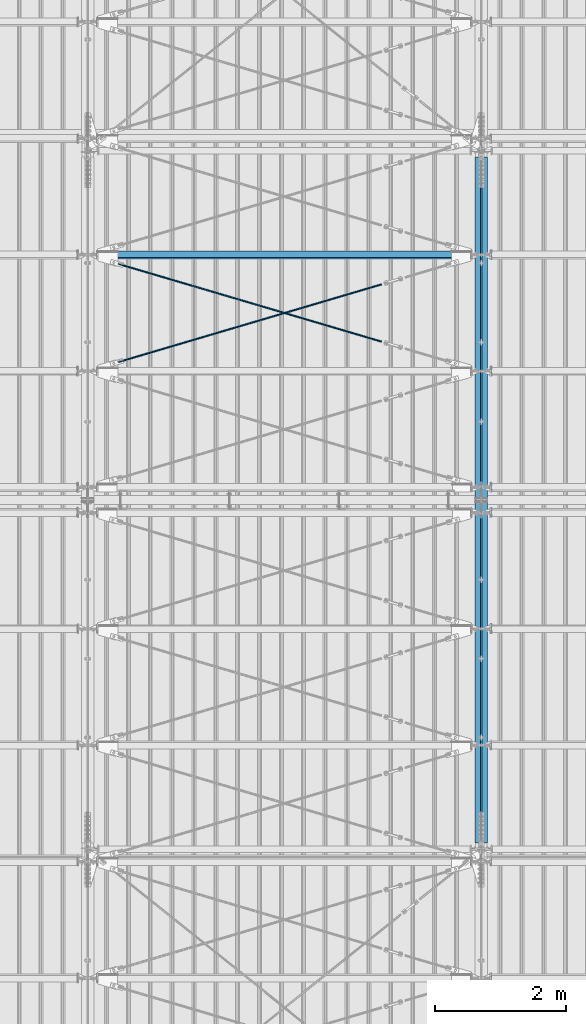
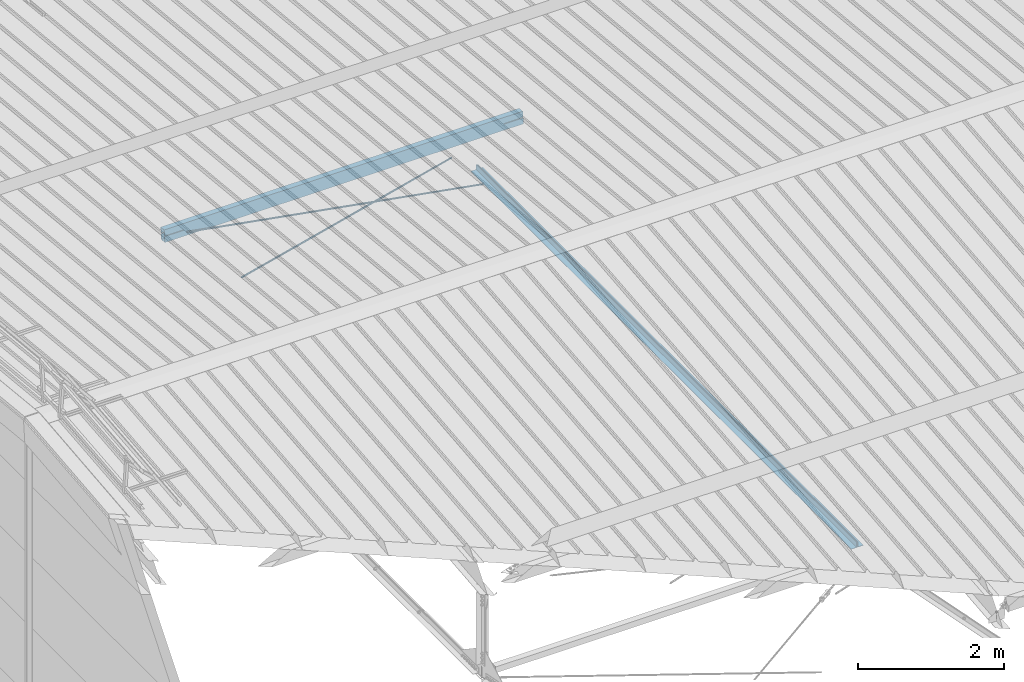
# One storey, part 249 of 709: 5 beams, 4 openings, 5 elements without a shape of their own.
"""IFC4 building model written with IfcOpenShell, lengths in millimetres."""

from ifc_helpers import new_model, si_unit, direction, frame, origin_with_axes, place, context, subcontext, project, spatial, line, indexed_curve, outline, extrude, polygons, material, element, aggregate, save


model = new_model("IFC4")

# Units and contexts
model_context = context("Model", 3, precision=0.2, world=origin_with_axes(), true_north=direction((0.0, 1.0)))
body_context = subcontext(model_context, "Body", "Model", "MODEL_VIEW")
reference_context = subcontext(model_context, "Reference", "Model", "MODEL_VIEW")
ifc_project = project(units=[si_unit("LENGTHUNIT", "METRE", prefix="MILLI"), si_unit("AREAUNIT", "SQUARE_METRE"), si_unit("VOLUMEUNIT", "CUBIC_METRE"), si_unit("MASSUNIT", "GRAM", prefix="KILO"), si_unit("TIMEUNIT", "SECOND"), si_unit("PLANEANGLEUNIT", "RADIAN"), si_unit("SOLIDANGLEUNIT", "STERADIAN"), si_unit("THERMODYNAMICTEMPERATUREUNIT", "DEGREE_CELSIUS"), si_unit("LUMINOUSINTENSITYUNIT", "LUMEN")], contexts=[model_context])

# Site, building, storey
site_placement = place(None, origin_with_axes())
site = spatial("IfcSite", under=ifc_project, at=site_placement, CompositionType="ELEMENT")
building_placement = place(site_placement, origin_with_axes())
building = spatial("IfcBuilding", under=site, at=building_placement, Name="Undefined", CompositionType="ELEMENT")
storey_placement = place(building_placement, origin_with_axes())
storey = spatial("IfcBuildingStorey", under=building, at=storey_placement, Name="Undefined", CompositionType="ELEMENT", Elevation=0.0)

# Assembly, beam
assembly_1_placement = place(storey_placement, frame((9949.0, 5673.0, 6045.00002), z_axis=(0.0, 0.0, 1.0), x_axis=(0.0, 1.0, 0.0)))
assembly_1 = element("IfcElementAssembly", 1, at=assembly_1_placement, inside=storey)
ifc_material_1 = material(Name="C345-5", Category="STEEL")
beam_1_placement = place(assembly_1_placement, origin_with_axes())
beam_1 = element("IfcBeam", 2, at=beam_1_placement, material=ifc_material_1, ObjectType="433", context=body_context, shape_type="Tessellation", body=[
    polygons([(100.0, -45.0, -45.0), (100.0, 45.0, -45.0), (10554.0, 45.0, -45.0), (10554.0, -45.0, -45.0), (100.0, 45.0, -39.0), (10554.0, 45.0, -39.0), (100.0, -39.0, -39.0), (10554.0, -39.0, -39.0), (100.0, -39.0, 45.0), (10554.0, -39.0, 45.0), (100.0, -45.0, 45.0), (10554.0, -45.0, 45.0)], [[[1, 2, 3, 4]], [[2, 5, 6, 3]], [[5, 7, 8, 6]], [[7, 9, 10, 8]], [[9, 11, 12, 10]], [[11, 1, 4, 12]], [[6, 8, 10, 12, 4, 3]], [[11, 9, 7, 5, 2, 1]]], closed=True),
])
aggregate(assembly_1, [beam_1])

assembly_2_placement = place(storey_placement, frame((10051.0, 16327.0, 6045.00002), z_axis=(0.0, 0.0, 1.0), x_axis=(0.0, -1.0, 0.0)))
assembly_2 = element("IfcElementAssembly", 3, at=assembly_2_placement, inside=storey)
beam_2_placement = place(assembly_2_placement, origin_with_axes())
beam_2 = element("IfcBeam", 4, at=beam_2_placement, material=ifc_material_1, ObjectType="434", context=body_context, shape_type="Tessellation", body=[
    polygons([(100.0, -45.0, -45.0), (100.0, 45.0, -45.0), (10554.0, 45.0, -45.0), (10554.0, -45.0, -45.0), (100.0, 45.0, -39.0), (10554.0, 45.0, -39.0), (100.0, -39.0, -39.0), (10554.0, -39.0, -39.0), (100.0, -39.0, 45.0), (10554.0, -39.0, 45.0), (100.0, -45.0, 45.0), (10554.0, -45.0, 45.0)], [[[1, 2, 3, 4]], [[2, 5, 6, 3]], [[5, 7, 8, 6]], [[7, 9, 10, 8]], [[9, 11, 12, 10]], [[11, 1, 4, 12]], [[6, 8, 10, 12, 4, 3]], [[11, 9, 7, 5, 2, 1]]], closed=True),
])
aggregate(assembly_2, [beam_2])

# Assembly, beam, voiding feature
assembly_3_placement = place(storey_placement, frame((4000.0, 12964.14591, 8040.08943), z_axis=(0.2847296511, -0.9538504697, 0.095385047), x_axis=(0.9586078582, 0.2833165921, -0.028331659)))
assembly_3 = element("IfcElementAssembly", 5, at=assembly_3_placement, inside=storey)
ifc_material_2 = material(Name="C355-5", Category="STEEL")
beam_3_placement = place(assembly_3_placement, origin_with_axes())
beam_3 = element("IfcBeam", 6, at=beam_3_placement, material=ifc_material_2, ObjectType="572", context=body_context, shape_type="Tessellation", body=[
    polygons([(4849.07659, 7.36122, 4.25), (4849.07659, 6.01041, 6.01041), (4849.07659, 4.25, 7.36122), (4849.07659, 2.19996, 8.21037), (4849.07659, 0.0, 8.5), (4849.07659, -2.19996, 8.21037), (4849.07659, -4.25, 7.36122), (4849.07659, -6.01041, 6.01041), (4849.07659, -7.36121, 4.25), (4849.07659, -8.21037, 2.19996), (4849.07659, -8.5, 0.0), (4849.07659, -8.21037, -2.19996), (4849.07659, -7.36121, -4.25), (4849.07659, -6.01041, -6.01041), (4849.07659, -4.25, -7.36122), (4849.07659, -2.19996, -8.21037), (4849.07659, 0.0, -8.5), (4849.07659, 2.19996, -8.21037), (4849.07659, 4.25, -7.36122), (4849.07659, 6.01041, -6.01041), (4849.07659, 7.36122, -4.25), (4849.07659, 8.21037, -2.19996), (4849.07659, 8.5, 0.0), (4849.07659, 8.21037, 2.19996), (4669.07659, 8.21037, 2.19996), (4669.07659, 7.36122, 4.25), (4669.07659, 6.01041, 6.01041), (4669.07659, 4.25, 7.36122), (4669.07659, 2.19996, 8.21037), (4669.07659, 0.0, 8.5), (4669.07659, -2.19996, 8.21037), (4669.07659, -4.25, 7.36122), (4669.07659, -6.01041, 6.01041), (4669.07659, -7.36121, 4.25), (4669.07659, -8.21037, 2.19996), (4669.07659, -8.5, 0.0), (4669.07659, -8.21037, -2.19996), (4669.07659, -7.36121, -4.25), (4669.07659, -6.01041, -6.01041), (4669.07659, -4.25, -7.36122), (4669.07659, -2.19996, -8.21037), (4669.07659, 0.0, -8.5), (4669.07659, 2.19996, -8.21037), (4669.07659, 4.25, -7.36122), (4669.07659, 6.01041, -6.01041), (4669.07659, 7.36122, -4.25), (4669.07659, 8.21037, -2.19996), (4669.07659, 8.5, 0.0), (4669.07659, 10.0, 0.0), (4669.07659, 9.65926, 2.58819), (4669.07659, 8.66025, 5.0), (4669.07659, 7.07107, 7.07107), (4669.07659, 5.0, 8.66025), (4669.07659, 2.58819, 9.65926), (4669.07659, 0.0, 10.0), (4669.07659, -2.58819, 9.65926), (4669.07659, -5.0, 8.66025), (4669.07659, -7.07107, 7.07107), (4669.07659, -8.66025, 5.0), (4669.07659, -9.65926, 2.58819), (4669.07659, -10.0, 0.0), (4669.07659, -9.65926, -2.58819), (4669.07659, -8.66025, -5.0), (4669.07659, -7.07107, -7.07107), (4669.07659, -5.0, -8.66025), (4669.07659, -2.58819, -9.65926), (4669.07659, 0.0, -10.0), (4669.07659, 2.58819, -9.65926), (4669.07659, 5.0, -8.66025), (4669.07659, 7.07107, -7.07107), (4669.07659, 8.66025, -5.0), (4669.07659, 9.65926, -2.58819), (483.68279, 2.58819, 9.65926), (483.68279, 5.0, 8.66025), (483.68279, 7.07107, 7.07107), (483.68279, 8.66025, 5.0), (483.68279, 9.65926, 2.58819), (483.68279, 10.0, 0.0), (483.68279, 9.65926, -2.58819), (483.68279, 8.66025, -5.0), (483.68279, 7.07107, -7.07107), (483.68279, 5.0, -8.66025), (483.68279, 2.58819, -9.65926), (483.68279, 0.0, -10.0), (483.68279, -2.58819, -9.65926), (483.68279, -5.0, -8.66025), (483.68279, -7.07107, -7.07107), (483.68279, -8.66025, -5.0), (483.68279, -9.65926, -2.58819), (483.68279, -10.0, 0.0), (483.68279, -9.65926, 2.58819), (483.68279, -8.66025, 5.0), (483.68279, -7.07107, 7.07107), (483.68279, -5.0, 8.66025), (483.68279, -2.58819, 9.65926), (483.68279, 0.0, 10.0)], [[[1, 2, 3, 4, 5, 6, 7, 8, 9, 10, 11, 12, 13, 14, 15, 16, 17, 18, 19, 20, 21, 22, 23, 24]], [[24, 25, 26, 1]], [[1, 26, 27, 2]], [[2, 27, 28, 3]], [[3, 28, 29, 4]], [[4, 29, 30, 5]], [[5, 30, 31, 6]], [[6, 31, 32, 7]], [[7, 32, 33, 8]], [[8, 33, 34, 9]], [[9, 34, 35, 10]], [[10, 35, 36, 11]], [[11, 36, 37, 12]], [[12, 37, 38, 13]], [[13, 38, 39, 14]], [[14, 39, 40, 15]], [[15, 40, 41, 16]], [[16, 41, 42, 17]], [[17, 42, 43, 18]], [[18, 43, 44, 19]], [[19, 44, 45, 20]], [[20, 45, 46, 21]], [[21, 46, 47, 22]], [[22, 47, 48, 23]], [[23, 48, 25, 24]], [[49, 50, 51, 52, 53, 54, 55, 56, 57, 58, 59, 60, 61, 62, 63, 64, 65, 66, 67, 68, 69, 70, 71, 72], [47, 46, 45, 44, 43, 42, 41, 40, 39, 38, 37, 36, 35, 34, 33, 32, 31, 30, 29, 28, 27, 26, 25, 48]], [[73, 74, 75, 76, 77, 78, 79, 80, 81, 82, 83, 84, 85, 86, 87, 88, 89, 90, 91, 92, 93, 94, 95, 96]], [[79, 78, 49, 72]], [[80, 79, 72, 71]], [[81, 80, 71, 70]], [[82, 81, 70, 69]], [[83, 82, 69, 68]], [[84, 83, 68, 67]], [[85, 84, 67, 66]], [[86, 85, 66, 65]], [[87, 86, 65, 64]], [[88, 87, 64, 63]], [[89, 88, 63, 62]], [[90, 89, 62, 61]], [[91, 90, 61, 60]], [[92, 91, 60, 59]], [[93, 92, 59, 58]], [[94, 93, 58, 57]], [[95, 94, 57, 56]], [[96, 95, 56, 55]], [[73, 96, 55, 54]], [[74, 73, 54, 53]], [[75, 74, 53, 52]], [[76, 75, 52, 51]], [[77, 76, 51, 50]], [[78, 77, 50, 49]]], closed=True),
])
voiding_feature_1_placement = place(beam_3_placement, frame((4849.07659, 0.0, 0.0), z_axis=(0.0, 1.0, 0.0), x_axis=(-1.0, 0.0, 0.0)))
element("IfcVoidingFeature", 7, at=voiding_feature_1_placement, cuts=beam_3, PredefinedType="HOLE", context=reference_context, identifier="Reference", shape_type="SolidModel", body=[
    extrude(outline(indexed_curve([(10.5, 0.0), (10.14222, 2.7176), (9.09327, 5.25), (7.42462, 7.42462), (5.25, 9.09327), (2.7176, 10.14222), (0.0, 10.5), (-2.7176, 10.14222), (-5.25, 9.09327), (-7.42462, 7.42462), (-9.09327, 5.25), (-10.14222, 2.7176), (-10.5, 0.0), (-10.14222, -2.7176), (-9.09327, -5.25), (-7.42462, -7.42462), (-5.25, -9.09327), (-2.7176, -10.14222), (0.0, -10.5), (2.7176, -10.14222), (5.25, -9.09327), (7.42462, -7.42462), (9.09327, -5.25), (10.14222, -2.7176)], segments=[line(1, 2, 3, 4, 5, 6, 7, 8, 9, 10, 11, 12, 13, 14, 15, 16, 17, 18, 19, 20, 21, 22, 23, 24, 1)])), frame((0.0, 0.0, 0.0), z_axis=(-1.0, 0.0, 0.0), x_axis=(0.0, 0.0, 1.0)), (0.0, 0.0, -1.0), 180.0),
])
aggregate(assembly_3, [beam_3])

assembly_4_placement = place(storey_placement, frame((4000.0, 14737.44615, 7862.7594), z_axis=(-0.2847296511, -0.9538504697, 0.095385047), x_axis=(0.9586078582, -0.2833165921, 0.028331659)))
assembly_4 = element("IfcElementAssembly", 8, at=assembly_4_placement, inside=storey)
beam_4_placement = place(assembly_4_placement, origin_with_axes())
beam_4 = element("IfcBeam", 9, at=beam_4_placement, material=ifc_material_2, ObjectType="572", context=body_context, shape_type="Tessellation", body=[
    polygons([(4849.07659, 7.36122, 4.25), (4849.07659, 6.01041, 6.01041), (4849.07659, 4.25, 7.36122), (4849.07659, 2.19996, 8.21037), (4849.07659, 0.0, 8.5), (4849.07659, -2.19996, 8.21037), (4849.07659, -4.25, 7.36122), (4849.07659, -6.01041, 6.01041), (4849.07659, -7.36121, 4.25), (4849.07659, -8.21037, 2.19996), (4849.07659, -8.5, 0.0), (4849.07659, -8.21037, -2.19996), (4849.07659, -7.36121, -4.25), (4849.07659, -6.01041, -6.01041), (4849.07659, -4.25, -7.36122), (4849.07659, -2.19996, -8.21037), (4849.07659, 0.0, -8.5), (4849.07659, 2.19996, -8.21037), (4849.07659, 4.25, -7.36122), (4849.07659, 6.01041, -6.01041), (4849.07659, 7.36122, -4.25), (4849.07659, 8.21037, -2.19996), (4849.07659, 8.5, 0.0), (4849.07659, 8.21037, 2.19996), (4669.07659, 8.21037, 2.19996), (4669.07659, 7.36122, 4.25), (4669.07659, 6.01041, 6.01041), (4669.07659, 4.25, 7.36122), (4669.07659, 2.19996, 8.21037), (4669.07659, 0.0, 8.5), (4669.07659, -2.19996, 8.21037), (4669.07659, -4.25, 7.36122), (4669.07659, -6.01041, 6.01041), (4669.07659, -7.36121, 4.25), (4669.07659, -8.21037, 2.19996), (4669.07659, -8.5, 0.0), (4669.07659, -8.21037, -2.19996), (4669.07659, -7.36121, -4.25), (4669.07659, -6.01041, -6.01041), (4669.07659, -4.25, -7.36122), (4669.07659, -2.19996, -8.21037), (4669.07659, 0.0, -8.5), (4669.07659, 2.19996, -8.21037), (4669.07659, 4.25, -7.36122), (4669.07659, 6.01041, -6.01041), (4669.07659, 7.36122, -4.25), (4669.07659, 8.21037, -2.19996), (4669.07659, 8.5, 0.0), (4669.07659, 10.0, 0.0), (4669.07659, 9.65926, 2.58819), (4669.07659, 8.66025, 5.0), (4669.07659, 7.07107, 7.07107), (4669.07659, 5.0, 8.66025), (4669.07659, 2.58819, 9.65926), (4669.07659, 0.0, 10.0), (4669.07659, -2.58819, 9.65926), (4669.07659, -5.0, 8.66025), (4669.07659, -7.07107, 7.07107), (4669.07659, -8.66025, 5.0), (4669.07659, -9.65926, 2.58819), (4669.07659, -10.0, 0.0), (4669.07659, -9.65926, -2.58819), (4669.07659, -8.66025, -5.0), (4669.07659, -7.07107, -7.07107), (4669.07659, -5.0, -8.66025), (4669.07659, -2.58819, -9.65926), (4669.07659, 0.0, -10.0), (4669.07659, 2.58819, -9.65926), (4669.07659, 5.0, -8.66025), (4669.07659, 7.07107, -7.07107), (4669.07659, 8.66025, -5.0), (4669.07659, 9.65926, -2.58819), (483.68279, 2.58819, 9.65926), (483.68279, 5.0, 8.66025), (483.68279, 7.07107, 7.07107), (483.68279, 8.66025, 5.0), (483.68279, 9.65926, 2.58819), (483.68279, 10.0, 0.0), (483.68279, 9.65926, -2.58819), (483.68279, 8.66025, -5.0), (483.68279, 7.07107, -7.07107), (483.68279, 5.0, -8.66025), (483.68279, 2.58819, -9.65926), (483.68279, 0.0, -10.0), (483.68279, -2.58819, -9.65926), (483.68279, -5.0, -8.66025), (483.68279, -7.07107, -7.07107), (483.68279, -8.66025, -5.0), (483.68279, -9.65926, -2.58819), (483.68279, -10.0, 0.0), (483.68279, -9.65926, 2.58819), (483.68279, -8.66025, 5.0), (483.68279, -7.07107, 7.07107), (483.68279, -5.0, 8.66025), (483.68279, -2.58819, 9.65926), (483.68279, 0.0, 10.0)], [[[1, 2, 3, 4, 5, 6, 7, 8, 9, 10, 11, 12, 13, 14, 15, 16, 17, 18, 19, 20, 21, 22, 23, 24]], [[24, 25, 26, 1]], [[1, 26, 27, 2]], [[2, 27, 28, 3]], [[3, 28, 29, 4]], [[4, 29, 30, 5]], [[5, 30, 31, 6]], [[6, 31, 32, 7]], [[7, 32, 33, 8]], [[8, 33, 34, 9]], [[9, 34, 35, 10]], [[10, 35, 36, 11]], [[11, 36, 37, 12]], [[12, 37, 38, 13]], [[13, 38, 39, 14]], [[14, 39, 40, 15]], [[15, 40, 41, 16]], [[16, 41, 42, 17]], [[17, 42, 43, 18]], [[18, 43, 44, 19]], [[19, 44, 45, 20]], [[20, 45, 46, 21]], [[21, 46, 47, 22]], [[22, 47, 48, 23]], [[23, 48, 25, 24]], [[49, 50, 51, 52, 53, 54, 55, 56, 57, 58, 59, 60, 61, 62, 63, 64, 65, 66, 67, 68, 69, 70, 71, 72], [47, 46, 45, 44, 43, 42, 41, 40, 39, 38, 37, 36, 35, 34, 33, 32, 31, 30, 29, 28, 27, 26, 25, 48]], [[73, 74, 75, 76, 77, 78, 79, 80, 81, 82, 83, 84, 85, 86, 87, 88, 89, 90, 91, 92, 93, 94, 95, 96]], [[79, 78, 49, 72]], [[80, 79, 72, 71]], [[81, 80, 71, 70]], [[82, 81, 70, 69]], [[83, 82, 69, 68]], [[84, 83, 68, 67]], [[85, 84, 67, 66]], [[86, 85, 66, 65]], [[87, 86, 65, 64]], [[88, 87, 64, 63]], [[89, 88, 63, 62]], [[90, 89, 62, 61]], [[91, 90, 61, 60]], [[92, 91, 60, 59]], [[93, 92, 59, 58]], [[94, 93, 58, 57]], [[95, 94, 57, 56]], [[96, 95, 56, 55]], [[73, 96, 55, 54]], [[74, 73, 54, 53]], [[75, 74, 53, 52]], [[76, 75, 52, 51]], [[77, 76, 51, 50]], [[78, 77, 50, 49]]], closed=True),
])
voiding_feature_2_placement = place(beam_4_placement, frame((4849.07659, 0.0, 0.0), z_axis=(0.0, 1.0, 0.0), x_axis=(-1.0, 0.0, 0.0)))
element("IfcVoidingFeature", 10, at=voiding_feature_2_placement, cuts=beam_4, PredefinedType="HOLE", context=reference_context, identifier="Reference", shape_type="SolidModel", body=[
    extrude(outline(indexed_curve([(10.5, 0.0), (10.14222, 2.7176), (9.09327, 5.25), (7.42462, 7.42462), (5.25, 9.09327), (2.7176, 10.14222), (0.0, 10.5), (-2.7176, 10.14222), (-5.25, 9.09327), (-7.42462, 7.42462), (-9.09327, 5.25), (-10.14222, 2.7176), (-10.5, 0.0), (-10.14222, -2.7176), (-9.09327, -5.25), (-7.42462, -7.42462), (-5.25, -9.09327), (-2.7176, -10.14222), (0.0, -10.5), (2.7176, -10.14222), (5.25, -9.09327), (7.42462, -7.42462), (9.09327, -5.25), (10.14222, -2.7176)], segments=[line(1, 2, 3, 4, 5, 6, 7, 8, 9, 10, 11, 12, 13, 14, 15, 16, 17, 18, 19, 20, 21, 22, 23, 24, 1)])), frame((0.0, 0.0, 0.0), z_axis=(-1.0, 0.0, 0.0), x_axis=(0.0, 0.0, 1.0)), (0.0, 0.0, -1.0), 180.0),
])
aggregate(assembly_4, [beam_4])

# Assembly, beam, voiding features
assembly_5_placement = place(storey_placement, frame((10000.0, 14736.65012, 7854.7991), z_axis=(0.0, -0.9950371902, 0.099503719), x_axis=(-1.0, 0.0, 0.0)))
assembly_5 = element("IfcElementAssembly", 11, at=assembly_5_placement, inside=storey)
ifc_material_3 = material(Name="C355", Category="STEEL")
beam_5_placement = place(assembly_5_placement, origin_with_axes())
beam_5 = element("IfcBeam", 12, at=beam_5_placement, material=ifc_material_3, ObjectType="566", context=body_context, shape_type="Tessellation", body=[
    polygons([(457.3028, -5.0, 50.0), (457.3028, -5.0, 46.0), (155.0, -5.0, 46.0), (155.0, -5.0, 50.0), (457.3028, 5.0, 50.0), (457.3028, 5.0, 46.0), (155.0, 5.0, 50.0), (155.0, 5.0, 46.0), (457.3028, -5.0, -46.0), (457.3028, -5.0, -50.0), (155.0, -5.0, -50.0), (155.0, -5.0, -46.0), (457.3028, 5.0, -46.0), (457.3028, 5.0, -50.0), (155.0, 5.0, -46.0), (155.0, 5.0, -50.0), (155.0, 96.0, 46.0), (155.0, 96.0, -46.0), (5845.0, 96.0, -46.0), (5845.0, 96.0, 46.0), (155.0, 100.0, -50.0), (5845.0, 100.0, -50.0), (5845.0, 5.0, -50.0), (5542.6972, 5.0, -50.0), (5542.6972, -5.0, -50.0), (5845.0, -5.0, -50.0), (5845.0, -100.0, -50.0), (155.0, -100.0, -50.0), (5845.00055, 5.0, -46.0), (5542.6972, 5.0, -46.0), (5542.6972, -5.0, -46.0), (5845.0, -5.0, -46.0), (155.0, -96.0, -46.0), (155.0, -96.0, 46.0), (5845.0, -96.0, 46.0), (5845.0, -96.0, -46.0), (5542.6972, -5.0, 50.0), (5542.6972, -5.0, 46.0), (5542.6972, 5.0, 46.0), (5542.6972, 5.0, 50.0), (5845.0, -5.0, 50.0), (5845.0, -5.0, 46.0), (5845.0, -100.0, 50.0), (155.0, -100.0, 50.0), (5845.0, 5.0, 46.0), (5845.00055, 5.0, 50.0), (5845.0, 100.0, 50.0), (155.0, 100.0, 50.0)], [[[1, 2, 3, 4]], [[5, 6, 2, 1]], [[7, 8, 6, 5]], [[9, 10, 11, 12]], [[13, 14, 10, 9]], [[15, 16, 14, 13]], [[17, 18, 19, 20]], [[21, 22, 23, 24, 25, 26, 27, 28, 11, 10, 14, 16]], [[29, 30, 24, 23]], [[31, 25, 24, 30]], [[32, 26, 25, 31]], [[33, 34, 35, 36]], [[37, 38, 39, 40]], [[41, 42, 38, 37]], [[43, 27, 26, 32, 36, 35, 42, 41]], [[44, 28, 27, 43]], [[34, 33, 12, 11, 28, 44, 4, 3]], [[17, 20, 45, 39, 38, 42, 35, 34, 3, 2, 6, 8]], [[46, 40, 39, 45]], [[20, 19, 29, 23, 22, 47, 46, 45]], [[21, 48, 47, 22]], [[4, 44, 43, 41, 37, 40, 46, 47, 48, 7, 5, 1]], [[48, 21, 16, 15, 18, 17, 8, 7]], [[12, 33, 36, 32, 31, 30, 29, 19, 18, 15, 13, 9]]], closed=True),
])
voiding_feature_3_placement = place(beam_5_placement, frame((5845.00055, 0.0, -92.98165), z_axis=(0.0, -1.0, 0.0), x_axis=(0.0, 0.0, 1.0)))
element("IfcVoidingFeature", 13, at=voiding_feature_3_placement, cuts=beam_5, Name="PLATE", PredefinedType="HOLE", context=reference_context, identifier="Reference", shape_type="SolidModel", body=[
    extrude(outline(indexed_curve([(0.0, 0.0), (185.9633, 0.0), (268.14324, 276.67769), (181.86854, 302.30336), (4.09476, 302.30336), (-82.17995, 276.67769)], segments=[line(1, 2, 3, 4, 5, 6, 1)])), frame((0.0, 0.0, 5.0), z_axis=(0.0, 0.0, 1.0), x_axis=(1.0, 0.0, 0.0)), (0.0, 0.0, -1.0), 10.0),
])
voiding_feature_4_placement = place(beam_5_placement, frame((154.99945, 0.0, 92.98165), z_axis=(0.0, -1.0, 0.0), x_axis=(0.0, 0.0, -1.0)))
element("IfcVoidingFeature", 14, at=voiding_feature_4_placement, cuts=beam_5, Name="PLATE", PredefinedType="HOLE", context=reference_context, identifier="Reference", shape_type="SolidModel", body=[
    extrude(outline(indexed_curve([(0.0, 0.0), (185.9633, 0.0), (268.14324, 276.67769), (181.86854, 302.30336), (4.09476, 302.30336), (-82.17995, 276.67769)], segments=[line(1, 2, 3, 4, 5, 6, 1)])), frame((0.0, 0.0, 5.0), z_axis=(0.0, 0.0, 1.0), x_axis=(1.0, 0.0, 0.0)), (0.0, 0.0, -1.0), 10.0),
])
aggregate(assembly_5, [beam_5])

save(model, "model.ifc")
